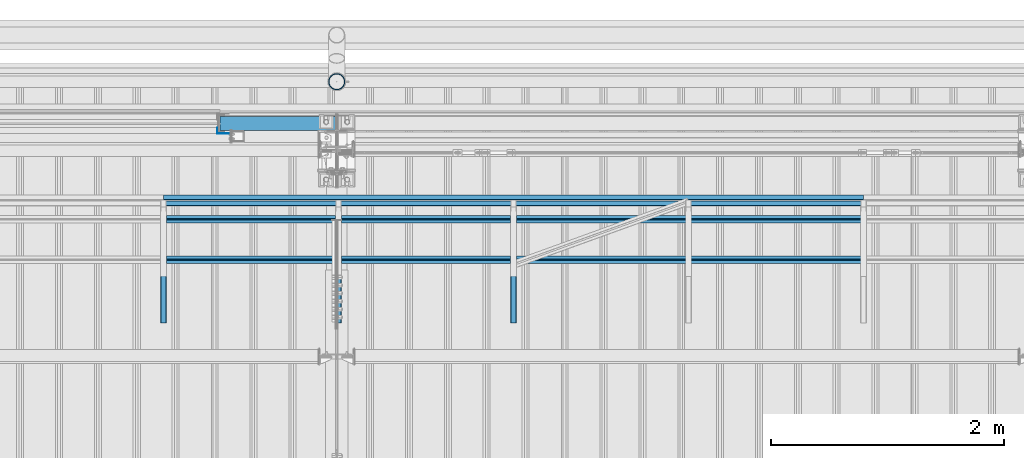
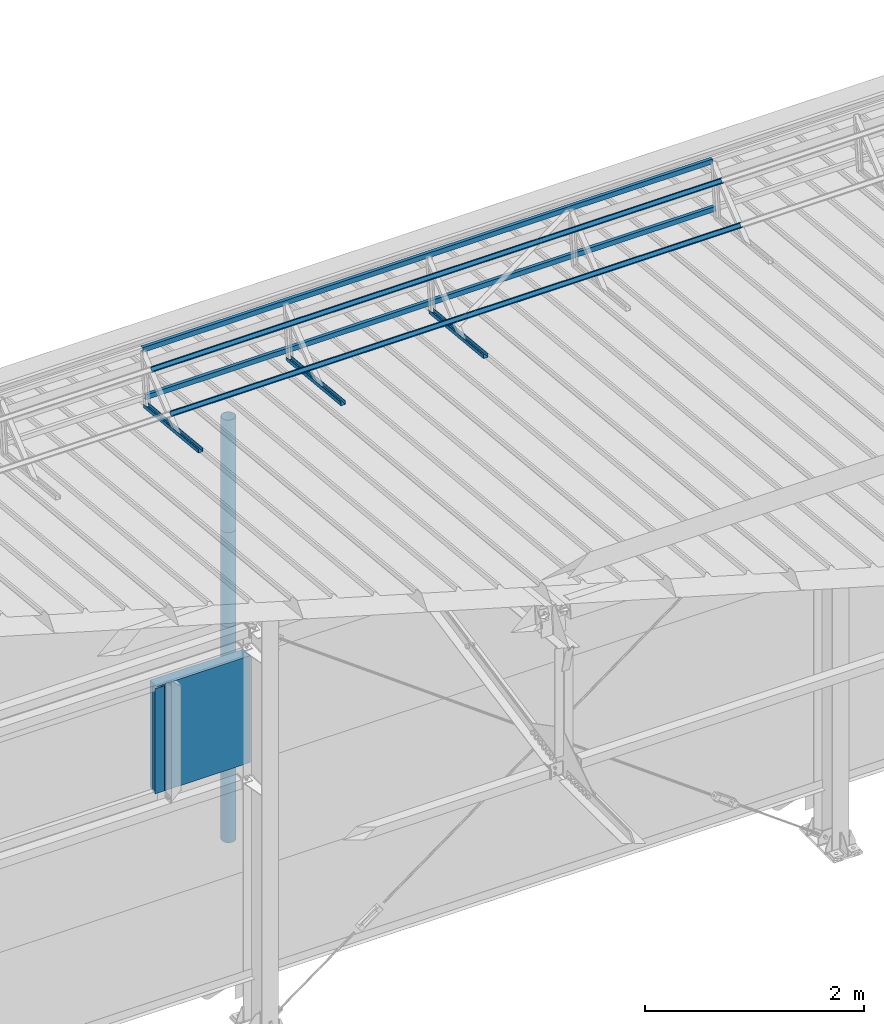
# One storey, part 59 of 709: 13 beams, 13 elements without a shape of their own.
"""IFC4 building model written with IfcOpenShell, lengths in millimetres."""

from ifc_helpers import new_model, si_unit, direction, frame, origin_with_axes, place, context, subcontext, project, spatial, line, indexed_curve, outline, extrude, material, element, aggregate, save


model = new_model("IFC4")

# Units and contexts
model_context = context("Model", 3, precision=0.2, world=origin_with_axes(), true_north=direction((0.0, 1.0)))
body_context = subcontext(model_context, "Body", "Model", "MODEL_VIEW")
ifc_project = project(units=[si_unit("LENGTHUNIT", "METRE", prefix="MILLI"), si_unit("AREAUNIT", "SQUARE_METRE"), si_unit("VOLUMEUNIT", "CUBIC_METRE"), si_unit("MASSUNIT", "GRAM", prefix="KILO"), si_unit("TIMEUNIT", "SECOND"), si_unit("PLANEANGLEUNIT", "RADIAN"), si_unit("SOLIDANGLEUNIT", "STERADIAN"), si_unit("THERMODYNAMICTEMPERATUREUNIT", "DEGREE_CELSIUS"), si_unit("LUMINOUSINTENSITYUNIT", "LUMEN")], contexts=[model_context])

# Site, building, storey
site_placement = place(None, origin_with_axes())
site = spatial("IfcSite", under=ifc_project, at=site_placement, CompositionType="ELEMENT")
building_placement = place(site_placement, origin_with_axes())
building = spatial("IfcBuilding", under=site, at=building_placement, Name="Undefined", CompositionType="ELEMENT")
storey_placement = place(building_placement, origin_with_axes())
storey = spatial("IfcBuildingStorey", under=building, at=storey_placement, Name="Undefined", CompositionType="ELEMENT", Elevation=0.0)

# Assembly, beam
assembly_1_placement = place(storey_placement, frame((23515.0, 21349.29926, 7565.33969), z_axis=(0.0, 0.099503719, 0.9950371902), x_axis=(0.0, -0.9950371902, 0.099503719)))
assembly_1 = element("IfcElementAssembly", 1, at=assembly_1_placement, inside=storey)
ifc_material_1 = material(Name="Steel_Undefined", Category="STEEL")
beam_1_placement = place(assembly_1_placement, origin_with_axes())
beam_1 = element("IfcBeam", 2, at=beam_1_placement, material=ifc_material_1, ObjectType="601", context=body_context, shape_type="SolidModel", body=[
    extrude(outline(indexed_curve([(-20.0, -25.0), (20.0, -25.0), (20.0, -22.5), (-17.5, -22.5), (-17.5, 22.5), (20.0, 22.5), (20.0, 25.0), (-20.0, 25.0)], segments=[line(1, 2, 3, 4, 5, 6, 7, 8, 1)])), frame((0.0, 0.0, 0.0), z_axis=(-1.0, 0.0, 0.0), x_axis=(0.0, 0.0, 1.0)), (0.0, 0.0, -1.0), 1000.0),
])
aggregate(assembly_1, [beam_1])

assembly_2_placement = place(storey_placement, frame((22015.0, 21349.29926, 7565.33969), z_axis=(0.0, 0.099503719, 0.9950371902), x_axis=(0.0, -0.9950371902, 0.099503719)))
assembly_2 = element("IfcElementAssembly", 3, at=assembly_2_placement, inside=storey)
beam_2_placement = place(assembly_2_placement, origin_with_axes())
beam_2 = element("IfcBeam", 4, at=beam_2_placement, material=ifc_material_1, ObjectType="601", context=body_context, shape_type="SolidModel", body=[
    extrude(outline(indexed_curve([(-20.0, -25.0), (20.0, -25.0), (20.0, -22.5), (-17.5, -22.5), (-17.5, 22.5), (20.0, 22.5), (20.0, 25.0), (-20.0, 25.0)], segments=[line(1, 2, 3, 4, 5, 6, 7, 8, 1)])), frame((0.0, 0.0, 0.0), z_axis=(-1.0, 0.0, 0.0), x_axis=(0.0, 0.0, 1.0)), (0.0, 0.0, -1.0), 1000.0),
])
aggregate(assembly_2, [beam_2])

assembly_3_placement = place(storey_placement, frame((26515.0, 21426.91216, 8140.47118), z_axis=(0.0, 0.9950371902, -0.099503719), x_axis=(-1.0, 0.0, 0.0)))
assembly_3 = element("IfcElementAssembly", 5, at=assembly_3_placement, inside=storey)
beam_3_placement = place(assembly_3_placement, origin_with_axes())
beam_3 = element("IfcBeam", 6, at=beam_3_placement, material=ifc_material_1, ObjectType="606", context=body_context, shape_type="SolidModel", body=[
    extrude(outline(indexed_curve([(-20.0, -25.0), (20.0, -25.0), (20.0, -22.5), (-17.5, -22.5), (-17.5, 22.5), (20.0, 22.5), (20.0, 25.0), (-20.0, 25.0)], segments=[line(1, 2, 3, 4, 5, 6, 7, 8, 1)])), frame((0.0, 0.0, 0.0), z_axis=(-1.0, 0.0, 0.0), x_axis=(0.0, 0.0, 1.0)), (0.0, 0.0, -1.0), 6000.0),
])
aggregate(assembly_3, [beam_3])

assembly_4_placement = place(storey_placement, frame((26515.0, 21377.1603, 7642.95259), z_axis=(0.0, 0.9950371902, -0.099503719), x_axis=(-1.0, 0.0, 0.0)))
assembly_4 = element("IfcElementAssembly", 7, at=assembly_4_placement, inside=storey)
beam_4_placement = place(assembly_4_placement, origin_with_axes())
beam_4 = element("IfcBeam", 8, at=beam_4_placement, material=ifc_material_1, ObjectType="606", context=body_context, shape_type="SolidModel", body=[
    extrude(outline(indexed_curve([(-20.0, -25.0), (20.0, -25.0), (20.0, -22.5), (-17.5, -22.5), (-17.5, 22.5), (20.0, 22.5), (20.0, 25.0), (-20.0, 25.0)], segments=[line(1, 2, 3, 4, 5, 6, 7, 8, 1)])), frame((0.0, 0.0, 0.0), z_axis=(-1.0, 0.0, 0.0), x_axis=(0.0, 0.0, 1.0)), (0.0, 0.0, -1.0), 6000.0),
])
aggregate(assembly_4, [beam_4])

assembly_5_placement = place(storey_placement, frame((26515.0, 21239.5552, 8031.29285), z_axis=(0.0, -0.6332377902, 0.7739572992), x_axis=(-1.0, 0.0, 0.0)))
assembly_5 = element("IfcElementAssembly", 9, at=assembly_5_placement, inside=storey)
beam_5_placement = place(assembly_5_placement, origin_with_axes())
beam_5 = element("IfcBeam", 10, at=beam_5_placement, material=ifc_material_1, ObjectType="606", context=body_context, shape_type="SolidModel", body=[
    extrude(outline(indexed_curve([(-20.0, -25.0), (20.0, -25.0), (20.0, -22.5), (-17.5, -22.5), (-17.5, 22.5), (20.0, 22.5), (20.0, 25.0), (-20.0, 25.0)], segments=[line(1, 2, 3, 4, 5, 6, 7, 8, 1)])), frame((0.0, 0.0, 0.0), z_axis=(-1.0, 0.0, 0.0), x_axis=(0.0, 0.0, 1.0)), (0.0, 0.0, -1.0), 6000.0),
])
aggregate(assembly_5, [beam_5])

assembly_6_placement = place(storey_placement, frame((26515.0, 20892.41357, 7747.26788), z_axis=(0.0, -0.6332377902, 0.7739572992), x_axis=(-1.0, 0.0, 0.0)))
assembly_6 = element("IfcElementAssembly", 11, at=assembly_6_placement, inside=storey)
beam_6_placement = place(assembly_6_placement, origin_with_axes())
beam_6 = element("IfcBeam", 12, at=beam_6_placement, material=ifc_material_1, ObjectType="606", context=body_context, shape_type="SolidModel", body=[
    extrude(outline(indexed_curve([(-20.0, -25.0), (20.0, -25.0), (20.0, -22.5), (-17.5, -22.5), (-17.5, 22.5), (20.0, 22.5), (20.0, 25.0), (-20.0, 25.0)], segments=[line(1, 2, 3, 4, 5, 6, 7, 8, 1)])), frame((0.0, 0.0, 0.0), z_axis=(-1.0, 0.0, 0.0), x_axis=(0.0, 0.0, 1.0)), (0.0, 0.0, -1.0), 6000.0),
])
aggregate(assembly_6, [beam_6])

assembly_7_placement = place(storey_placement, frame((20515.0, 21349.29926, 7565.33969), z_axis=(0.0, 0.099503719, 0.9950371902), x_axis=(0.0, -0.9950371902, 0.099503719)))
assembly_7 = element("IfcElementAssembly", 13, at=assembly_7_placement, inside=storey)
beam_7_placement = place(assembly_7_placement, origin_with_axes())
beam_7 = element("IfcBeam", 14, at=beam_7_placement, material=ifc_material_1, ObjectType="601", context=body_context, shape_type="SolidModel", body=[
    extrude(outline(indexed_curve([(-20.0, -25.0), (20.0, -25.0), (20.0, -22.5), (-17.5, -22.5), (-17.5, 22.5), (20.0, 22.5), (20.0, 25.0), (-20.0, 25.0)], segments=[line(1, 2, 3, 4, 5, 6, 7, 8, 1)])), frame((0.0, 0.0, 0.0), z_axis=(-1.0, 0.0, 0.0), x_axis=(0.0, 0.0, 1.0)), (0.0, 0.0, -1.0), 1000.0),
])
aggregate(assembly_7, [beam_7])

assembly_8_placement = place(storey_placement, frame((21000.0, 22060.0, 3275.0), z_axis=(0.0, 0.0, -1.0), x_axis=(1.0, 0.0, 0.0)))
assembly_8 = element("IfcElementAssembly", 15, at=assembly_8_placement, inside=storey)
ifc_material_2 = material(Name="Insulation", Category="Insulation")
beam_8_placement = place(assembly_8_placement, origin_with_axes())
beam_8 = element("IfcBeam", 16, at=beam_8_placement, material=ifc_material_2, ObjectType="P-110", context=body_context, shape_type="SolidModel", body=[
    extrude(outline(indexed_curve([(-595.0, -60.0), (595.0, -60.0), (595.0, 60.0), (-595.0, 60.0)], segments=[line(1, 2, 3, 4, 1)])), frame((0.0, 0.0, 0.0), z_axis=(-1.0, 0.0, 0.0), x_axis=(0.0, 0.0, 1.0)), (0.0, 0.0, -1.0), 990.0),
])
aggregate(assembly_8, [beam_8])

assembly_9_placement = place(storey_placement, frame((20975.0, 22001.0, 3870.0), z_axis=(0.0, -1.0, 0.0), x_axis=(0.0, 0.0, -1.0)))
assembly_9 = element("IfcElementAssembly", 17, at=assembly_9_placement, inside=storey)
beam_9_placement = place(assembly_9_placement, origin_with_axes())
beam_9 = element("IfcBeam", 18, at=beam_9_placement, material=ifc_material_1, context=body_context, shape_type="SolidModel", body=[
    extrude(outline(indexed_curve([(-25.0, -1.0), (25.0, -1.0), (25.0, 99.0), (23.0, 99.0), (23.0, 1.0), (-25.0, 1.0)], segments=[line(1, 2, 3, 4, 5, 6, 1)])), frame((0.0, 0.0, 0.0), z_axis=(-1.0, 0.0, 0.0), x_axis=(0.0, 0.0, 1.0)), (0.0, 0.0, -1.0), 1170.0),
])
aggregate(assembly_9, [beam_9])

assembly_10_placement = place(storey_placement, frame((22000.0, 22420.0, 6276.92297), z_axis=(0.0, -1.0, 0.0), x_axis=(0.0, 0.0, -1.0)))
assembly_10 = element("IfcElementAssembly", 19, at=assembly_10_placement, inside=storey)
beam_10_placement = place(assembly_10_placement, origin_with_axes())
beam_10 = element("IfcBeam", 20, at=beam_10_placement, material=ifc_material_1, ObjectType="614", context=body_context, shape_type="SolidModel", body=[
    extrude(outline(indexed_curve([(70.0, 0.0), (69.61653, 7.31699), (68.47033, 14.55382), (66.57396, 21.63119), (63.94818, 28.47157), (60.62178, 35.0), (56.63119, 41.14497), (52.02014, 46.83914), (46.83914, 52.02014), (41.14497, 56.63119), (35.0, 60.62178), (28.47157, 63.94818), (21.63119, 66.57396), (14.55382, 68.47033), (7.31699, 69.61653), (0.0, 70.0), (-7.31699, 69.61653), (-14.55382, 68.47033), (-21.63119, 66.57396), (-28.47157, 63.94818), (-35.0, 60.62178), (-41.14497, 56.63119), (-46.83914, 52.02014), (-52.02014, 46.83914), (-56.63119, 41.14497), (-60.62178, 35.0), (-63.94818, 28.47157), (-66.57396, 21.63119), (-68.47033, 14.55382), (-69.61653, 7.31699), (-70.0, 0.0), (-69.61653, -7.31699), (-68.47033, -14.55382), (-66.57396, -21.63119), (-63.94818, -28.47157), (-60.62178, -35.0), (-56.63119, -41.14497), (-52.02014, -46.83914), (-46.83914, -52.02014), (-41.14497, -56.63119), (-35.0, -60.62178), (-28.47157, -63.94818), (-21.63119, -66.57396), (-14.55382, -68.47033), (-7.31699, -69.61653), (0.0, -70.0), (7.31699, -69.61653), (14.55382, -68.47033), (21.63119, -66.57396), (28.47157, -63.94818), (35.0, -60.62178), (41.14497, -56.63119), (46.83914, -52.02014), (52.02014, -46.83914), (56.63119, -41.14497), (60.62178, -35.0), (63.94818, -28.47157), (66.57396, -21.63119), (68.47033, -14.55382), (69.61653, -7.31699)], segments=[line(1, 2, 3, 4, 5, 6, 7, 8, 9, 10, 11, 12, 13, 14, 15, 16, 17, 18, 19, 20, 21, 22, 23, 24, 25, 26, 27, 28, 29, 30, 31, 32, 33, 34, 35, 36, 37, 38, 39, 40, 41, 42, 43, 44, 45, 46, 47, 48, 49, 50, 51, 52, 53, 54, 55, 56, 57, 58, 59, 60, 1)]), holes=[indexed_curve([(65.0, 0.0), (64.64392, -6.79435), (63.57959, -13.51426), (61.81867, -20.0861), (59.38045, -26.43788), (56.29165, -32.5), (52.5861, -38.20604), (48.30441, -43.49349), (43.49349, -48.30441), (38.20604, -52.5861), (32.5, -56.29165), (26.43788, -59.38045), (20.0861, -61.81867), (13.51426, -63.57959), (6.79435, -64.64392), (0.0, -65.0), (-6.79435, -64.64392), (-13.51426, -63.57959), (-20.0861, -61.81867), (-26.43788, -59.38045), (-32.5, -56.29165), (-38.20604, -52.5861), (-43.49349, -48.30441), (-48.30441, -43.49349), (-52.5861, -38.20604), (-56.29165, -32.5), (-59.38045, -26.43788), (-61.81867, -20.0861), (-63.57959, -13.51426), (-64.64392, -6.79435), (-65.0, 0.0), (-64.64392, 6.79435), (-63.57959, 13.51426), (-61.81867, 20.0861), (-59.38045, 26.43788), (-56.29165, 32.5), (-52.5861, 38.20604), (-48.30441, 43.49349), (-43.49349, 48.30441), (-38.20604, 52.5861), (-32.5, 56.29165), (-26.43788, 59.38045), (-20.0861, 61.81867), (-13.51426, 63.57959), (-6.79435, 64.64392), (0.0, 65.0), (6.79435, 64.64392), (13.51426, 63.57959), (20.0861, 61.81867), (26.43788, 59.38045), (32.5, 56.29165), (38.20604, 52.5861), (43.49349, 48.30441), (48.30441, 43.49349), (52.5861, 38.20604), (56.29165, 32.5), (59.38045, 26.43788), (61.81867, 20.0861), (63.57959, 13.51426), (64.64392, 6.79435)], segments=[line(1, 2, 3, 4, 5, 6, 7, 8, 9, 10, 11, 12, 13, 14, 15, 16, 17, 18, 19, 20, 21, 22, 23, 24, 25, 26, 27, 28, 29, 30, 31, 32, 33, 34, 35, 36, 37, 38, 39, 40, 41, 42, 43, 44, 45, 46, 47, 48, 49, 50, 51, 52, 53, 54, 55, 56, 57, 58, 59, 60, 1)])]), frame((0.0, 0.0, 0.0), z_axis=(-1.0, 0.0, 0.0), x_axis=(0.0, 0.0, 1.0)), (0.0, 0.0, -1.0), 1250.0),
])
aggregate(assembly_10, [beam_10])

assembly_11_placement = place(storey_placement, frame((22000.0, 22420.0, 5126.92297), z_axis=(0.0, -1.0, 0.0), x_axis=(0.0, 0.0, -1.0)))
assembly_11 = element("IfcElementAssembly", 21, at=assembly_11_placement, inside=storey)
beam_11_placement = place(assembly_11_placement, origin_with_axes())
beam_11 = element("IfcBeam", 22, at=beam_11_placement, material=ifc_material_1, ObjectType="614", context=body_context, shape_type="SolidModel", body=[
    extrude(outline(indexed_curve([(70.0, 0.0), (69.61653, 7.31699), (68.47033, 14.55382), (66.57396, 21.63119), (63.94818, 28.47157), (60.62178, 35.0), (56.63119, 41.14497), (52.02014, 46.83914), (46.83914, 52.02014), (41.14497, 56.63119), (35.0, 60.62178), (28.47157, 63.94818), (21.63119, 66.57396), (14.55382, 68.47033), (7.31699, 69.61653), (0.0, 70.0), (-7.31699, 69.61653), (-14.55382, 68.47033), (-21.63119, 66.57396), (-28.47157, 63.94818), (-35.0, 60.62178), (-41.14497, 56.63119), (-46.83914, 52.02014), (-52.02014, 46.83914), (-56.63119, 41.14497), (-60.62178, 35.0), (-63.94818, 28.47157), (-66.57396, 21.63119), (-68.47033, 14.55382), (-69.61653, 7.31699), (-70.0, 0.0), (-69.61653, -7.31699), (-68.47033, -14.55382), (-66.57396, -21.63119), (-63.94818, -28.47157), (-60.62178, -35.0), (-56.63119, -41.14497), (-52.02014, -46.83914), (-46.83914, -52.02014), (-41.14497, -56.63119), (-35.0, -60.62178), (-28.47157, -63.94818), (-21.63119, -66.57396), (-14.55382, -68.47033), (-7.31699, -69.61653), (0.0, -70.0), (7.31699, -69.61653), (14.55382, -68.47033), (21.63119, -66.57396), (28.47157, -63.94818), (35.0, -60.62178), (41.14497, -56.63119), (46.83914, -52.02014), (52.02014, -46.83914), (56.63119, -41.14497), (60.62178, -35.0), (63.94818, -28.47157), (66.57396, -21.63119), (68.47033, -14.55382), (69.61653, -7.31699)], segments=[line(1, 2, 3, 4, 5, 6, 7, 8, 9, 10, 11, 12, 13, 14, 15, 16, 17, 18, 19, 20, 21, 22, 23, 24, 25, 26, 27, 28, 29, 30, 31, 32, 33, 34, 35, 36, 37, 38, 39, 40, 41, 42, 43, 44, 45, 46, 47, 48, 49, 50, 51, 52, 53, 54, 55, 56, 57, 58, 59, 60, 1)]), holes=[indexed_curve([(65.0, 0.0), (64.64392, -6.79435), (63.57959, -13.51426), (61.81867, -20.0861), (59.38045, -26.43788), (56.29165, -32.5), (52.5861, -38.20604), (48.30441, -43.49349), (43.49349, -48.30441), (38.20604, -52.5861), (32.5, -56.29165), (26.43788, -59.38045), (20.0861, -61.81867), (13.51426, -63.57959), (6.79435, -64.64392), (0.0, -65.0), (-6.79435, -64.64392), (-13.51426, -63.57959), (-20.0861, -61.81867), (-26.43788, -59.38045), (-32.5, -56.29165), (-38.20604, -52.5861), (-43.49349, -48.30441), (-48.30441, -43.49349), (-52.5861, -38.20604), (-56.29165, -32.5), (-59.38045, -26.43788), (-61.81867, -20.0861), (-63.57959, -13.51426), (-64.64392, -6.79435), (-65.0, 0.0), (-64.64392, 6.79435), (-63.57959, 13.51426), (-61.81867, 20.0861), (-59.38045, 26.43788), (-56.29165, 32.5), (-52.5861, 38.20604), (-48.30441, 43.49349), (-43.49349, 48.30441), (-38.20604, 52.5861), (-32.5, 56.29165), (-26.43788, 59.38045), (-20.0861, 61.81867), (-13.51426, 63.57959), (-6.79435, 64.64392), (0.0, 65.0), (6.79435, 64.64392), (13.51426, 63.57959), (20.0861, 61.81867), (26.43788, 59.38045), (32.5, 56.29165), (38.20604, 52.5861), (43.49349, 48.30441), (48.30441, 43.49349), (52.5861, 38.20604), (56.29165, 32.5), (59.38045, 26.43788), (61.81867, 20.0861), (63.57959, 13.51426), (64.64392, 6.79435)], segments=[line(1, 2, 3, 4, 5, 6, 7, 8, 9, 10, 11, 12, 13, 14, 15, 16, 17, 18, 19, 20, 21, 22, 23, 24, 25, 26, 27, 28, 29, 30, 31, 32, 33, 34, 35, 36, 37, 38, 39, 40, 41, 42, 43, 44, 45, 46, 47, 48, 49, 50, 51, 52, 53, 54, 55, 56, 57, 58, 59, 60, 1)])]), frame((0.0, 0.0, 0.0), z_axis=(-1.0, 0.0, 0.0), x_axis=(0.0, 0.0, 1.0)), (0.0, 0.0, -1.0), 1250.0),
])
aggregate(assembly_11, [beam_11])

assembly_12_placement = place(storey_placement, frame((22000.0, 22420.0, 3976.92297), z_axis=(0.0, -1.0, 0.0), x_axis=(0.0, 0.0, -1.0)))
assembly_12 = element("IfcElementAssembly", 23, at=assembly_12_placement, inside=storey)
beam_12_placement = place(assembly_12_placement, origin_with_axes())
beam_12 = element("IfcBeam", 24, at=beam_12_placement, material=ifc_material_1, ObjectType="614", context=body_context, shape_type="SolidModel", body=[
    extrude(outline(indexed_curve([(70.0, 0.0), (69.61653, 7.31699), (68.47033, 14.55382), (66.57396, 21.63119), (63.94818, 28.47157), (60.62178, 35.0), (56.63119, 41.14497), (52.02014, 46.83914), (46.83914, 52.02014), (41.14497, 56.63119), (35.0, 60.62178), (28.47157, 63.94818), (21.63119, 66.57396), (14.55382, 68.47033), (7.31699, 69.61653), (0.0, 70.0), (-7.31699, 69.61653), (-14.55382, 68.47033), (-21.63119, 66.57396), (-28.47157, 63.94818), (-35.0, 60.62178), (-41.14497, 56.63119), (-46.83914, 52.02014), (-52.02014, 46.83914), (-56.63119, 41.14497), (-60.62178, 35.0), (-63.94818, 28.47157), (-66.57396, 21.63119), (-68.47033, 14.55382), (-69.61653, 7.31699), (-70.0, 0.0), (-69.61653, -7.31699), (-68.47033, -14.55382), (-66.57396, -21.63119), (-63.94818, -28.47157), (-60.62178, -35.0), (-56.63119, -41.14497), (-52.02014, -46.83914), (-46.83914, -52.02014), (-41.14497, -56.63119), (-35.0, -60.62178), (-28.47157, -63.94818), (-21.63119, -66.57396), (-14.55382, -68.47033), (-7.31699, -69.61653), (0.0, -70.0), (7.31699, -69.61653), (14.55382, -68.47033), (21.63119, -66.57396), (28.47157, -63.94818), (35.0, -60.62178), (41.14497, -56.63119), (46.83914, -52.02014), (52.02014, -46.83914), (56.63119, -41.14497), (60.62178, -35.0), (63.94818, -28.47157), (66.57396, -21.63119), (68.47033, -14.55382), (69.61653, -7.31699)], segments=[line(1, 2, 3, 4, 5, 6, 7, 8, 9, 10, 11, 12, 13, 14, 15, 16, 17, 18, 19, 20, 21, 22, 23, 24, 25, 26, 27, 28, 29, 30, 31, 32, 33, 34, 35, 36, 37, 38, 39, 40, 41, 42, 43, 44, 45, 46, 47, 48, 49, 50, 51, 52, 53, 54, 55, 56, 57, 58, 59, 60, 1)]), holes=[indexed_curve([(65.0, 0.0), (64.64392, -6.79435), (63.57959, -13.51426), (61.81867, -20.0861), (59.38045, -26.43788), (56.29165, -32.5), (52.5861, -38.20604), (48.30441, -43.49349), (43.49349, -48.30441), (38.20604, -52.5861), (32.5, -56.29165), (26.43788, -59.38045), (20.0861, -61.81867), (13.51426, -63.57959), (6.79435, -64.64392), (0.0, -65.0), (-6.79435, -64.64392), (-13.51426, -63.57959), (-20.0861, -61.81867), (-26.43788, -59.38045), (-32.5, -56.29165), (-38.20604, -52.5861), (-43.49349, -48.30441), (-48.30441, -43.49349), (-52.5861, -38.20604), (-56.29165, -32.5), (-59.38045, -26.43788), (-61.81867, -20.0861), (-63.57959, -13.51426), (-64.64392, -6.79435), (-65.0, 0.0), (-64.64392, 6.79435), (-63.57959, 13.51426), (-61.81867, 20.0861), (-59.38045, 26.43788), (-56.29165, 32.5), (-52.5861, 38.20604), (-48.30441, 43.49349), (-43.49349, 48.30441), (-38.20604, 52.5861), (-32.5, 56.29165), (-26.43788, 59.38045), (-20.0861, 61.81867), (-13.51426, 63.57959), (-6.79435, 64.64392), (0.0, 65.0), (6.79435, 64.64392), (13.51426, 63.57959), (20.0861, 61.81867), (26.43788, 59.38045), (32.5, 56.29165), (38.20604, 52.5861), (43.49349, 48.30441), (48.30441, 43.49349), (52.5861, 38.20604), (56.29165, 32.5), (59.38045, 26.43788), (61.81867, 20.0861), (63.57959, 13.51426), (64.64392, 6.79435)], segments=[line(1, 2, 3, 4, 5, 6, 7, 8, 9, 10, 11, 12, 13, 14, 15, 16, 17, 18, 19, 20, 21, 22, 23, 24, 25, 26, 27, 28, 29, 30, 31, 32, 33, 34, 35, 36, 37, 38, 39, 40, 41, 42, 43, 44, 45, 46, 47, 48, 49, 50, 51, 52, 53, 54, 55, 56, 57, 58, 59, 60, 1)])]), frame((0.0, 0.0, 0.0), z_axis=(-1.0, 0.0, 0.0), x_axis=(0.0, 0.0, 1.0)), (0.0, 0.0, -1.0), 1250.0),
])
aggregate(assembly_12, [beam_12])

assembly_13_placement = place(storey_placement, frame((22000.0, 22420.0, 2826.92297), z_axis=(0.0, -1.0, 0.0), x_axis=(0.0, 0.0, -1.0)))
assembly_13 = element("IfcElementAssembly", 25, at=assembly_13_placement, inside=storey)
beam_13_placement = place(assembly_13_placement, origin_with_axes())
beam_13 = element("IfcBeam", 26, at=beam_13_placement, material=ifc_material_1, ObjectType="614", context=body_context, shape_type="SolidModel", body=[
    extrude(outline(indexed_curve([(70.0, 0.0), (69.61653, 7.31699), (68.47033, 14.55382), (66.57396, 21.63119), (63.94818, 28.47157), (60.62178, 35.0), (56.63119, 41.14497), (52.02014, 46.83914), (46.83914, 52.02014), (41.14497, 56.63119), (35.0, 60.62178), (28.47157, 63.94818), (21.63119, 66.57396), (14.55382, 68.47033), (7.31699, 69.61653), (0.0, 70.0), (-7.31699, 69.61653), (-14.55382, 68.47033), (-21.63119, 66.57396), (-28.47157, 63.94818), (-35.0, 60.62178), (-41.14497, 56.63119), (-46.83914, 52.02014), (-52.02014, 46.83914), (-56.63119, 41.14497), (-60.62178, 35.0), (-63.94818, 28.47157), (-66.57396, 21.63119), (-68.47033, 14.55382), (-69.61653, 7.31699), (-70.0, 0.0), (-69.61653, -7.31699), (-68.47033, -14.55382), (-66.57396, -21.63119), (-63.94818, -28.47157), (-60.62178, -35.0), (-56.63119, -41.14497), (-52.02014, -46.83914), (-46.83914, -52.02014), (-41.14497, -56.63119), (-35.0, -60.62178), (-28.47157, -63.94818), (-21.63119, -66.57396), (-14.55382, -68.47033), (-7.31699, -69.61653), (0.0, -70.0), (7.31699, -69.61653), (14.55382, -68.47033), (21.63119, -66.57396), (28.47157, -63.94818), (35.0, -60.62178), (41.14497, -56.63119), (46.83914, -52.02014), (52.02014, -46.83914), (56.63119, -41.14497), (60.62178, -35.0), (63.94818, -28.47157), (66.57396, -21.63119), (68.47033, -14.55382), (69.61653, -7.31699)], segments=[line(1, 2, 3, 4, 5, 6, 7, 8, 9, 10, 11, 12, 13, 14, 15, 16, 17, 18, 19, 20, 21, 22, 23, 24, 25, 26, 27, 28, 29, 30, 31, 32, 33, 34, 35, 36, 37, 38, 39, 40, 41, 42, 43, 44, 45, 46, 47, 48, 49, 50, 51, 52, 53, 54, 55, 56, 57, 58, 59, 60, 1)]), holes=[indexed_curve([(65.0, 0.0), (64.64392, -6.79435), (63.57959, -13.51426), (61.81867, -20.0861), (59.38045, -26.43788), (56.29165, -32.5), (52.5861, -38.20604), (48.30441, -43.49349), (43.49349, -48.30441), (38.20604, -52.5861), (32.5, -56.29165), (26.43788, -59.38045), (20.0861, -61.81867), (13.51426, -63.57959), (6.79435, -64.64392), (0.0, -65.0), (-6.79435, -64.64392), (-13.51426, -63.57959), (-20.0861, -61.81867), (-26.43788, -59.38045), (-32.5, -56.29165), (-38.20604, -52.5861), (-43.49349, -48.30441), (-48.30441, -43.49349), (-52.5861, -38.20604), (-56.29165, -32.5), (-59.38045, -26.43788), (-61.81867, -20.0861), (-63.57959, -13.51426), (-64.64392, -6.79435), (-65.0, 0.0), (-64.64392, 6.79435), (-63.57959, 13.51426), (-61.81867, 20.0861), (-59.38045, 26.43788), (-56.29165, 32.5), (-52.5861, 38.20604), (-48.30441, 43.49349), (-43.49349, 48.30441), (-38.20604, 52.5861), (-32.5, 56.29165), (-26.43788, 59.38045), (-20.0861, 61.81867), (-13.51426, 63.57959), (-6.79435, 64.64392), (0.0, 65.0), (6.79435, 64.64392), (13.51426, 63.57959), (20.0861, 61.81867), (26.43788, 59.38045), (32.5, 56.29165), (38.20604, 52.5861), (43.49349, 48.30441), (48.30441, 43.49349), (52.5861, 38.20604), (56.29165, 32.5), (59.38045, 26.43788), (61.81867, 20.0861), (63.57959, 13.51426), (64.64392, 6.79435)], segments=[line(1, 2, 3, 4, 5, 6, 7, 8, 9, 10, 11, 12, 13, 14, 15, 16, 17, 18, 19, 20, 21, 22, 23, 24, 25, 26, 27, 28, 29, 30, 31, 32, 33, 34, 35, 36, 37, 38, 39, 40, 41, 42, 43, 44, 45, 46, 47, 48, 49, 50, 51, 52, 53, 54, 55, 56, 57, 58, 59, 60, 1)])]), frame((0.0, 0.0, 0.0), z_axis=(-1.0, 0.0, 0.0), x_axis=(0.0, 0.0, 1.0)), (0.0, 0.0, -1.0), 1250.0),
])
aggregate(assembly_13, [beam_13])

save(model, "model.ifc")
